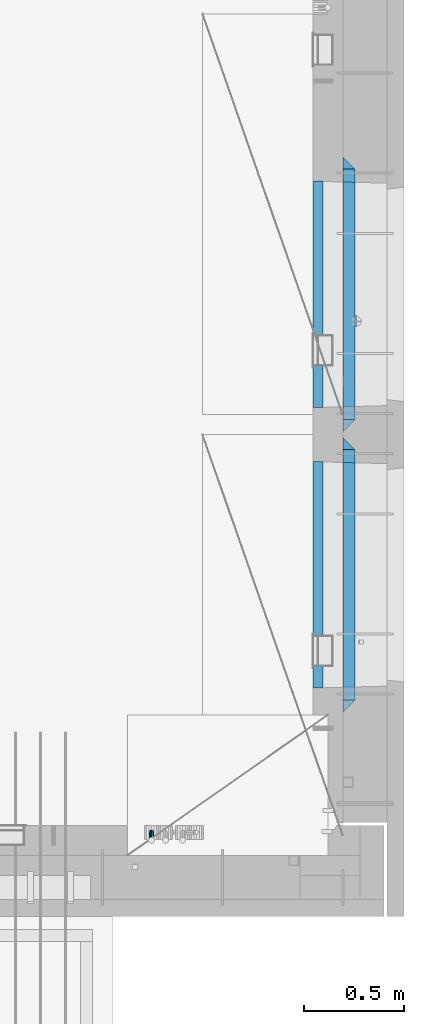
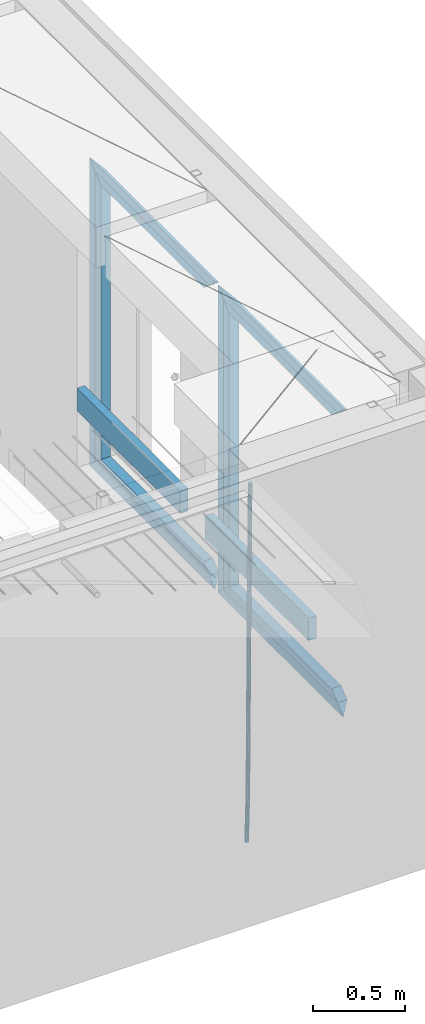
# One storey, part 130 of 352: 15 beams, 2 elements without a shape of their own.
"""IFC2X3 building model written with IfcOpenShell, lengths in millimetres."""

import ifcopenshell
import ifcopenshell.guid

model = None  # the IFC model being written
_history = None  # IfcOwnerHistory: only IFC2X3 demands one
_inside = {}  # id of a spatial element -> (the spatial element, [elements in it])
_under = {}  # id of a project, library or spatial element -> (it, [spatial elements below it])
_declared = {}  # id of a project -> (the project, [libraries it declares])
_typed = {}  # id of a type object -> (the type object, [elements of that type])
_made_of = {}  # id of a material, layer set ... -> (it, [elements and type objects made of it])


def new_model(schema):
    """Start an empty IFC model of exactly this schema.

    Asked for "IFC4X3", IfcOpenShell would pick the latest addendum, in which some entities
    have other attributes; the version numbers below select the first issue.
    IFC2X3 requires an IfcOwnerHistory on every rooted entity: one is made here for all.
    """
    global model, _history
    if schema == "IFC4X3":
        model = ifcopenshell.file(schema_version=(4, 3, 0, 0))
    else:
        model = ifcopenshell.file(schema=schema)
    _inside.clear()
    _under.clear()
    _declared.clear()
    _typed.clear()
    _made_of.clear()
    _history = None
    if model.schema == "IFC2X3":
        org = make("IfcOrganization", Name="unknown")
        user = make(
            "IfcPersonAndOrganization",
            ThePerson=make("IfcPerson", FamilyName="unknown"),
            TheOrganization=org,
        )
        app = make(
            "IfcApplication",
            ApplicationDeveloper=org,
            Version="unknown",
            ApplicationFullName="unknown",
            ApplicationIdentifier="unknown",
        )
        _history = make(
            "IfcOwnerHistory",
            OwningUser=user,
            OwningApplication=app,
            ChangeAction="ADDED",
            CreationDate=0,
        )
    return model


def make(cls, **values):
    """One entity of the class cls with the attributes given. An attribute that is None is left unset."""
    return model.create_entity(
        cls, **{name: value for name, value in values.items() if value is not None}
    )


def rooted(cls, **values):
    """An entity with a GlobalId (a new one), such as an element, a storey or a relation."""
    return make(cls, GlobalId=ifcopenshell.guid.new(), OwnerHistory=_history, **values)


def si_unit(unit_type, name, prefix=None):
    """IfcSIUnit, for example si_unit("LENGTHUNIT", "METRE", prefix="MILLI")."""
    return make("IfcSIUnit", UnitType=unit_type, Prefix=prefix, Name=name)


def assignment(units):
    """IfcUnitAssignment: the units of a project."""
    return None if units is None else make("IfcUnitAssignment", Units=units)


def point(xyz):
    """IfcCartesianPoint."""
    return None if xyz is None else make("IfcCartesianPoint", Coordinates=xyz)


def direction(xyz):
    """IfcDirection."""
    return None if xyz is None else make("IfcDirection", DirectionRatios=xyz)


def frame(location, z_axis=None, x_axis=None):
    """IfcAxis2Placement3D, a coordinate frame: its origin and axes. An axis left out is left unset."""
    return make(
        "IfcAxis2Placement3D",
        Location=point(location),
        Axis=direction(z_axis),
        RefDirection=direction(x_axis),
    )


def origin_with_axes():
    """The frame at (0, 0, 0) with the z axis (0, 0, 1) and the x axis (1, 0, 0) written out."""
    return frame((0.0, 0.0, 0.0), z_axis=(0.0, 0.0, 1.0), x_axis=(1.0, 0.0, 0.0))


def place(relative_to, where):
    """IfcLocalPlacement: puts the frame where relative to a parent placement (None: the world)."""
    return make(
        "IfcLocalPlacement", PlacementRelTo=relative_to, RelativePlacement=where
    )


def context(
    kind, dimensions, precision=None, world=None, true_north=None, identifier=None
):
    """IfcGeometricRepresentationContext, for example the 3D "Model" context."""
    return make(
        "IfcGeometricRepresentationContext",
        ContextIdentifier=identifier,
        ContextType=kind,
        CoordinateSpaceDimension=dimensions,
        Precision=precision,
        WorldCoordinateSystem=world,
        TrueNorth=true_north,
    )


def subcontext(parent, identifier, kind, view, scale=None):
    """IfcGeometricRepresentationSubContext, for example "Body" below "Model"."""
    return make(
        "IfcGeometricRepresentationSubContext",
        ContextIdentifier=identifier,
        ContextType=kind,
        ParentContext=parent,
        TargetScale=scale,
        TargetView=view,
    )


def project(units=None, contexts=None):
    """IfcProject with its units and contexts."""
    return rooted(
        "IfcProject",
        Name="project",
        RepresentationContexts=contexts,
        UnitsInContext=assignment(units),
    )


def spatial(cls, under=None, at=None, **own):
    """A site, building, storey or space (cls), placed at a placement, below another one or the project."""
    s = rooted(cls, ObjectPlacement=at, **own)
    if under is not None:
        _under.setdefault(under.id(), (under, []))[1].append(s)
    return s


def faces_of(points, faces, orient=None, outer=None):
    """IfcFace entities. A face is a list of loops; a loop is a list of indices into points, from 0.

    orient and outer hold one flag for each loop. By default every Orientation is true, the
    first loop of a face is its IfcFaceOuterBound and the others are IfcFaceBound.
    """
    made = []
    for i, loops in enumerate(faces):
        bounds = []
        for j, loop in enumerate(loops):
            is_outer = j == 0 if outer is None else outer[i][j]
            bounds.append(
                make(
                    "IfcFaceOuterBound" if is_outer else "IfcFaceBound",
                    Bound=make("IfcPolyLoop", Polygon=[points[k] for k in loop]),
                    Orientation=True if orient is None else orient[i][j],
                )
            )
        made.append(make("IfcFace", Bounds=bounds))
    return made


def faceted_brep(points, faces, orient=None, outer=None, voids=None):
    """IfcFacetedBrep: a solid bounded by flat faces; with voids (closed shells), ...WithVoids."""
    shared = [point(p) for p in points]
    hull = make("IfcClosedShell", CfsFaces=faces_of(shared, faces, orient, outer))
    if voids is None:
        return make("IfcFacetedBrep", Outer=hull)
    return make(
        "IfcFacetedBrepWithVoids",
        Outer=hull,
        Voids=[
            make(cls, CfsFaces=faces_of(shared, fs, o, b)) for cls, fs, o, b in voids
        ],
    )


def shape(context_of_items, identifier, shape_type, items):
    """IfcShapeRepresentation: the items that make up one representation, for example the "Body"."""
    return make(
        "IfcShapeRepresentation",
        ContextOfItems=context_of_items,
        RepresentationIdentifier=identifier,
        RepresentationType=shape_type,
        Items=items,
    )


def material(Name=None, Category=None):
    """IfcMaterial."""
    return make("IfcMaterial", Name=Name, Category=Category)


def made_of(thing, what):
    """Note that an element or type object is made of a material, layer set ...; save() writes the relation."""
    if what is not None:
        _made_of.setdefault(what.id(), (what, []))[1].append(thing)
    return thing


def type_object(cls, material=None, **own):
    """A type object (cls), such as IfcWallType, which elements share."""
    return made_of(rooted(cls, **own), material)


def element(
    cls,
    number,
    at=None,
    inside=None,
    cuts=None,
    type_object=None,
    material=None,
    context=None,
    identifier="Body",
    shape_type=None,
    held_by="IfcProductDefinitionShape",
    body=None,
    shapes=None,
    **own,
):
    """One element of the class cls, such as IfcWall. Its Tag is "e" and its number.

    at: its placement. inside: the storey or other place that contains it. cuts: it is an
    opening in that element (IfcRelVoidsElement). A single representation is given by context,
    identifier, shape_type and body (its items); several are given by shapes. held_by: the class
    of the entity that holds the representations. save() writes the other relations.
    """
    e = rooted(cls, Tag="e%d" % number, ObjectPlacement=at, **own)
    if body is not None:
        shapes = [shape(context, identifier, shape_type, body)]
    if shapes is not None:
        e.Representation = make(held_by, Representations=shapes)
    if inside is not None:
        _inside.setdefault(inside.id(), (inside, []))[1].append(e)
    if cuts is not None:
        rooted(
            "IfcRelVoidsElement", RelatingBuildingElement=cuts, RelatedOpeningElement=e
        )
    if type_object is not None:
        _typed.setdefault(type_object.id(), (type_object, []))[1].append(e)
    return made_of(e, material)


def aggregate(whole, parts):
    """IfcRelAggregates: a whole, such as a stair, and the parts it consists of."""
    return rooted("IfcRelAggregates", RelatingObject=whole, RelatedObjects=parts)


def save(model, path):
    """Write the relations noted so far, then the file.

    IfcRelAggregates (storeys below a building ...), IfcRelContainedInSpatialStructure (elements
    in a storey), IfcRelDefinesByType, IfcRelAssociatesMaterial and IfcRelDeclares: one each for
    every whole, place, type object, material and project.
    """
    for whole, parts in _under.values():
        aggregate(whole, parts)
    for where, things in _inside.values():
        rooted(
            "IfcRelContainedInSpatialStructure",
            RelatedElements=things,
            RelatingStructure=where,
        )
    for kind, things in _typed.values():
        rooted("IfcRelDefinesByType", RelatedObjects=things, RelatingType=kind)
    for what, things in _made_of.values():
        rooted("IfcRelAssociatesMaterial", RelatedObjects=things, RelatingMaterial=what)
    for by, libraries in _declared.values():
        rooted("IfcRelDeclares", RelatingContext=by, RelatedDefinitions=libraries)
    model.write(path)


model = new_model("IFC2X3")

# Units and contexts
model_context = context("Model", 3, precision=1e-05, world=origin_with_axes())
body_context = subcontext(model_context, "Body", "Model", "MODEL_VIEW")
ifc_project = project(units=[si_unit("LENGTHUNIT", "METRE", prefix="MILLI"), si_unit("AREAUNIT", "SQUARE_METRE"), si_unit("VOLUMEUNIT", "CUBIC_METRE"), si_unit("MASSUNIT", "GRAM", prefix="KILO"), si_unit("TIMEUNIT", "SECOND"), si_unit("PLANEANGLEUNIT", "RADIAN"), si_unit("SOLIDANGLEUNIT", "STERADIAN"), si_unit("THERMODYNAMICTEMPERATUREUNIT", "DEGREE_CELSIUS"), si_unit("LUMINOUSINTENSITYUNIT", "LUMEN")], contexts=[model_context])

# Site, building, storey
site_placement = place(None, origin_with_axes())
site = spatial("IfcSite", under=ifc_project, at=site_placement, CompositionType="ELEMENT")
building_placement = place(site_placement, origin_with_axes())
building = spatial("IfcBuilding", under=site, at=building_placement, CompositionType="ELEMENT")
storey_placement = place(building_placement, origin_with_axes())
storey = spatial("IfcBuildingStorey", under=building, at=storey_placement, Name="6", CompositionType="ELEMENT", Elevation=0.0)

# Assembly, beam
assembly_1_placement = place(storey_placement, origin_with_axes())
assembly_1 = element("IfcElementAssembly", 1, at=assembly_1_placement, inside=storey, AssemblyPlace="NOTDEFINED", PredefinedType="REINFORCEMENT_UNIT")
ifc_material_1 = material()
beam_type_1 = type_object("IfcBeamType", Name="D25", PredefinedType="NOTDEFINED")
beam_1_placement = place(assembly_1_placement, frame((34104.9999999961, 7965.00000227913, 96990.0), z_axis=(0.00020576299992186, -0.999642804629538, -0.0267249099901004), x_axis=(-4.30000201928125e-08, -0.0267249099948059, 0.999642825806181)))
beam_1 = element("IfcBeam", 2, at=beam_1_placement, type_object=beam_type_1, material=ifc_material_1, Name="JM25", ObjectType="D25", context=body_context, shape_type="Brep", body=[
    faceted_brep([(-7.41420080885291e-08, -12.5, -3.63797880709171e-12), (-6.42030499875546e-08, -10.8253175473074, -6.25000000000364), (60.4103898235917, -10.8253175318459, -6.2499999938409), (60.4103898269532, -12.4999999845422, 6.16273609921336e-09), (-3.70782800018787e-08, -6.25000000000364, -10.8253175473074), (60.4103898202884, -6.24999998454587, -10.8253175411446), (-1.45519152283669e-11, -3.63797880709171e-12, -12.5), (60.4103898179019, 1.54577719513327e-08, -12.4999999938373), (3.70637280866504e-08, 6.25, -10.8253175473074), (60.410389817087, 6.25000001545777, -10.825317541141), (6.42030499875546e-08, 10.8253175473001, -6.25000000000364), (60.410389818062, 10.8253175627578, -6.24999999383726), (7.41420080885291e-08, 12.4999999999927, 0.0), (60.4103898205503, 12.5000000154541, 6.16273609921336e-09), (6.42176019027829e-08, 10.8253175473001, 6.24999999999636), (60.4103898238973, 10.8253175627651, 6.2500000061591), (3.70928319171071e-08, 6.24999999999636, 10.8253175473037), (60.4103898272151, 6.25000001546141, 10.8253175534664), (1.45519152283669e-11, -3.63797880709171e-12, 12.4999999999964), (60.4103898296162, 1.54541339725256e-08, 12.5000000061591), (-3.7049176171422e-08, -6.25000000000364, 10.8253175473001), (60.4103898304165, -6.24999998454587, 10.8253175534701), (-6.41884980723262e-08, -10.8253175473074, 6.25), (60.4103898294561, -10.8253175318459, 6.25000000616637), (61.0324985728803, -10.8253175316895, -6.24999999377542), (60.991802792938, -12.4999999843931, 6.22458173893392e-09), (61.0622854283865, -6.24999998437852, -10.8253175410755), (61.0731819955545, 1.5628756955266e-08, -12.4999999937718), (61.0622685480339, 6.25000001562512, -10.8253175410791), (61.032469335245, 10.8253175629216, -6.24999999377178), (60.9917690322181, 12.5000000156033, 6.22458173893392e-09), (60.9510732522613, 10.8253175629034, 6.25000000621731), (60.9212863967696, 6.25000001558874, 10.8253175535247), (60.9103898296162, 1.55814632307738e-08, 12.5000000062137), (60.9213032771368, -6.24999998441126, 10.8253175535174), (60.9511024898966, -10.8253175317113, 6.25000000621731), (61.6545545670233, -10.8253158516927, -6.24189838219536), (61.573166454793, -12.499998414296, 0.00757164385504439), (61.7141257553885, -6.24999822394238, -10.8168280205282), (61.7359179680789, 1.80548886419274e-06, -12.491368569139), (61.7140919992817, 6.25000177601396, -10.8168282403167), (61.6544960997562, 10.8253192428383, -6.2418987628771), (61.5730989426083, 12.5000015856094, 0.0075712042817031), (61.4917108303925, 10.8253190230062, 6.25704123032847), (61.4321396420273, 6.25000139525582, 10.8319708686649), (61.4103474293224, 1.36582457344048e-06, 12.5065114172721), (61.4321733981196, -6.24999860470052, 10.8319710884571), (61.4917692976451, -10.8253160715249, 6.25704161101385), (176.524302641745, -10.8250056210964, -4.74584321979273), (176.442914529529, -12.4996881836996, 1.50362680625403), (176.583873830095, -6.24968799334965, -9.3207728581292), (176.605666042786, 0.000312036081595579, -10.9953134067364), (176.583840074018, 6.25031200660669, -9.32077307791769), (176.524244174492, 10.8256294734347, -4.74584360047811), (176.44284701733, 12.5003118162058, 1.50362636668069), (176.361458905099, 10.8256292535989, 7.75309639272746), (176.301887716749, 6.25031162585219, 12.3280260310676), (176.280095504058, 0.000311596420942806, 14.0025665796711), (176.301921472827, -6.24968837410415, 12.3280262508561), (176.361517372367, -10.8250058409321, 7.75309677341284), (177.085397012124, -10.8250041057399, -4.73853556792164), (176.983633547483, -12.4996867233749, 1.51066909103247), (177.159881729676, -6.24968643771717, -9.31327097355097), (177.187129580227, 0.000313606451527448, -10.987740468332), (177.159839524218, 6.25031356221734, -9.31327130338468), (177.085323910098, 10.8256309887511, -4.73853613920801), (176.983549136537, 12.5003132764905, 1.51066843136869), (176.881785671867, 10.8256306588555, 7.7598730903228), (176.80730095433, 6.25031299082912, 12.3346084959521), (176.780053103794, 0.000312946667690994, 14.0090779907332), (176.807343159802, -6.2496870091054, 12.3346088257895), (176.881858773908, -10.8250044356355, 7.7598736616128), (177.646431799818, -10.8250018318176, -4.72756919822132), (177.524295146417, -12.4996845320202, 1.52123723245313), (177.735828462886, -6.24968410334986, -9.30201312475765), (177.768531371941, 0.00031596292683389, -10.9763759912421), (177.735777808921, 6.25031589654827, -9.30201361973741), (177.646344064575, 10.8256332626152, -4.72757005553649), (177.524193838486, 12.5003154677688, 1.52123624250817), (177.402057185071, 10.8256327675663, 7.77004267317898), (177.312660521988, 6.2503150390985, 12.3444865997226), (177.279957612933, 0.00031497282179771, 14.0188494661961), (177.312711175953, -6.24968496079964, 12.3444870946951), (177.402144920314, -10.8250023268702, 7.77004353049415), (299.377443161706, -10.8245084454466, -2.34813158632096), (299.255306508276, -12.4991911456491, 3.90067484435349), (299.466839824803, -6.24919071697514, -6.92257551286093), (299.499542733873, 0.0008093492979242, -8.59693837933446), (299.466789170867, 6.250809282923, -6.92257600783341), (299.377355426492, 10.8261266489935, -2.34813244364341), (299.255205200388, 12.5008088541435, 3.90067385440125), (299.133068546944, 10.826126153941, 10.1494802850757), (299.043671883861, 6.25080842546959, 14.7239242116229), (299.010968974762, 0.000808359200163977, 16.3982870780892), (299.043722537797, -6.24919157442127, 14.7239247065918), (299.133156282158, -10.8245089404954, 10.1494811423981), (299.98561436501, -10.8245059804758, -2.33624385599614), (299.97179243555, -12.4991882411778, 3.91467976726199), (299.995742293278, -6.24918857328521, -6.91223722345239), (299.999447243041, 0.000811375455668895, -8.58716690387519), (299.995736475976, 6.25081142679483, -6.91223684201032), (299.985604289133, 10.8261291142808, -2.33624319533556), (299.971750386685, 12.5008117588586, 3.91467993563856), (299.957928457196, 10.8261294971744, 10.1656035610831), (299.947800528913, 6.25081208998381, 14.7415969285394), (299.944095579151, 0.00081214124293183, 16.4165266089549), (299.947806346216, -6.24918791008895, 14.7415965471009), (299.957938533058, -10.8245055975785, 10.1656029004225), (300.593832239858, -10.8245078794353, -2.34543881707941), (300.688302931099, -12.4991904788549, 3.90384712594823), (300.524685350189, -6.24919022474205, -6.92023371784308), (300.499390115292, 0.000809814544481924, -8.59472497713432), (300.524724372954, 6.25080977519247, -6.92023401429469), (300.593899829313, 10.8261272150703, -2.34543933054374), (300.688380976673, 12.5008095210287, 3.90384653304136), (300.782851667915, 10.8261269216127, 10.1531324760799), (300.851998557599, 6.25080926691589, 14.7279273768363), (300.877293792495, 0.000809227632998955, 16.4024186361276), (300.851959534804, -6.24919073302226, 14.7279276732806), (300.782784078474, -10.8245081728965, 10.153132989537), (2293.32930409742, -10.8307295605009, -32.4713622331001), (2293.42377478865, -12.5054121599169, -26.2220762900724), (2293.26015720774, -6.2554119058077, -37.0461571338565), (2293.23486197284, -0.00541186651753378, -38.7206483931477), (2293.26019623051, 6.24458809413409, -37.0461574303008), (2293.32937168686, 10.8199055340046, -32.4713627465644), (2293.42385283421, 12.4945878399631, -26.2220768829684), (2293.51832352545, 10.8199052405434, -19.972790939948), (2293.58747041514, 6.24458758585388, -15.3979960391844), (2293.61276565003, -0.00541245343265473, -13.7235047798931), (2293.58743139236, -6.25541241408428, -15.3979957427327), (2293.51825593603, -10.8307298539585, -19.9727904264691), (2294.0420846676, -10.8307317859326, -32.4821379598216), (2294.03681932652, -12.5054140739521, -26.2313442200393), (2294.06778164886, -6.2554144273563, -37.0583666982457), (2294.10702478497, -0.00541458957013674, -38.7338336404937), (2294.14929890928, 6.24458531819619, -37.0595987724118), (2294.18327670435, 10.8199028679592, -32.4842719748667), (2294.1998538474, 12.4945854171456, -26.2338083683717), (2294.19458850632, 10.819903129126, -19.9830146285858), (2294.16889152506, 6.24458577054975, -15.4067858901581), (2294.12964838895, -0.0054140672327776, -13.7313189479173), (2294.08737426462, -6.2554139749991, -15.4055538159919), (2294.05339646956, -10.8307315247621, -19.9808806135297), (2294.75482297382, -10.84002603931, -32.4726521173216), (2294.64982751427, -12.513407826169, -26.2231856868602), (2294.87535820232, -6.26594539088183, -37.0476186524102), (2294.97913588268, -0.0167870967634371, -38.7222267036377), (2295.0383488692, 6.23299192477134, -37.0477663960555), (2295.03713108998, 10.8087684320271, -32.4729080168181), (2294.97580884799, 12.4844668051373, -26.2234811741473), (2294.87081338844, 10.8110850182784, -19.9740147436787), (2294.7502781599, 6.23700436985018, -15.3990482086047), (2294.64650047956, -0.0121539242718427, -13.7244401573698), (2294.58728749304, -6.26193294580662, -15.3989004649666), (2294.58850527227, -10.8377094530588, -19.9737588441894), (2316.44667268227, -11.1228921988077, -32.1839550346631), (2316.34167722271, -12.7962739856739, -25.9344886042054), (2316.56720791078, -6.54881155039038, -36.7589215697517), (2316.67098559113, -0.299653256264719, -38.4335296209792), (2316.73019857766, 5.95012576527006, -36.759069313397), (2316.72898079845, 10.5259022725259, -32.1842109341669), (2316.66765855643, 12.2016006456361, -25.9347840914961), (2316.56266309689, 10.5282188587698, -19.6853176610275), (2316.44212786836, 5.95413821035254, -15.1103511259389), (2316.33835018802, -0.295020083769487, -13.4357430747186), (2316.27913720149, -6.54479910530426, -15.1102033823008), (2316.28035498071, -11.1205756125637, -19.685061761531), (2317.13234804722, -11.1318335458927, -32.1748293731798), (2317.04181141085, -12.8054038787741, -25.9251705100723), (2317.2154741603, -6.5572650749491, -36.7502937866229), (2317.26891617525, -0.307450393454928, -38.4255717558117), (2317.27835434731, 5.94297770185585, -36.7517739018112), (2317.24125972588, 10.5192220504723, -32.1773930078925), (2317.16757178486, 12.1950816748285, -25.9281307404563), (2317.0770351485, 10.5215113419545, -19.6784718773561), (2316.99390903539, 5.94694287101083, -15.1030074639057), (2316.94046702047, -0.302871810494253, -13.4277294947169), (2316.9310288484, -6.55329990579412, -15.1015273487101), (2316.96812346982, -11.1295442544142, -19.6759082426288), (2317.81808136747, -11.1298054502913, -32.1659056455355), (2317.74200467508, -12.803315894289, -25.9160547315114), (2317.86379538118, -6.55536082026447, -36.7418676070083), (2317.8668976831, -0.305700748642266, -38.417815303761), (2317.82655701396, 5.94458339541234, -36.7446799039099), (2317.75358262347, 10.5207330230332, -32.1707766866384), (2317.66752794063, 12.1965725370646, -25.9216793252963), (2317.59145124823, 10.5230620930706, -19.6718284112721), (2317.54573723453, 5.94861746304377, -15.0958664497994), (2317.54263493262, -0.301042608574789, -13.4199187530394), (2317.58297560175, -6.55132675263303, -15.0930541529051), (2317.65594999224, -11.1274763802539, -19.6669573701693), (2417.81884292323, -10.831603083323, -30.8687911350135), (2417.74276623082, -12.505113527317, -24.618940220982), (2417.86455693691, -6.25715845329614, -35.4447530964935), (2417.86765923884, -0.00749838167394046, -37.1207007932499), (2417.82731856969, 6.24278576237703, -35.4475653933878), (2417.75434417921, 10.8189353900088, -30.8736621761236), (2417.66828949639, 12.494774904033, -24.6245648147851), (2417.59221280397, 10.8212644600353, -18.3747139007501), (2417.54649879028, 6.2468198300121, -13.79875193927), (2417.54339648837, -0.00284024161010166, -12.1228042425173), (2417.5837371575, -6.25312438566107, -13.795939642383), (2417.65671154798, -10.8292740132893, -18.3698428596399)], [[[0, 1, 2, 3]], [[1, 4, 5, 2]], [[4, 6, 7, 5]], [[6, 8, 9, 7]], [[8, 10, 11, 9]], [[10, 12, 13, 11]], [[12, 14, 15, 13]], [[14, 16, 17, 15]], [[16, 18, 19, 17]], [[18, 20, 21, 19]], [[20, 22, 23, 21]], [[22, 0, 3, 23]], [[22, 20, 18, 16, 14, 12, 10, 8, 6, 4, 1, 0]], [[3, 2, 24, 25]], [[2, 5, 26, 24]], [[5, 7, 27, 26]], [[7, 9, 28, 27]], [[9, 11, 29, 28]], [[11, 13, 30, 29]], [[13, 15, 31, 30]], [[15, 17, 32, 31]], [[17, 19, 33, 32]], [[19, 21, 34, 33]], [[21, 23, 35, 34]], [[23, 3, 25, 35]], [[25, 24, 36, 37]], [[24, 26, 38, 36]], [[26, 27, 39, 38]], [[27, 28, 40, 39]], [[28, 29, 41, 40]], [[29, 30, 42, 41]], [[30, 31, 43, 42]], [[31, 32, 44, 43]], [[32, 33, 45, 44]], [[33, 34, 46, 45]], [[34, 35, 47, 46]], [[35, 25, 37, 47]], [[37, 36, 48, 49]], [[36, 38, 50, 48]], [[38, 39, 51, 50]], [[39, 40, 52, 51]], [[40, 41, 53, 52]], [[41, 42, 54, 53]], [[42, 43, 55, 54]], [[43, 44, 56, 55]], [[44, 45, 57, 56]], [[45, 46, 58, 57]], [[46, 47, 59, 58]], [[47, 37, 49, 59]], [[49, 48, 60, 61]], [[48, 50, 62, 60]], [[50, 51, 63, 62]], [[51, 52, 64, 63]], [[52, 53, 65, 64]], [[53, 54, 66, 65]], [[54, 55, 67, 66]], [[55, 56, 68, 67]], [[56, 57, 69, 68]], [[57, 58, 70, 69]], [[58, 59, 71, 70]], [[59, 49, 61, 71]], [[61, 60, 72, 73]], [[60, 62, 74, 72]], [[62, 63, 75, 74]], [[63, 64, 76, 75]], [[64, 65, 77, 76]], [[65, 66, 78, 77]], [[66, 67, 79, 78]], [[67, 68, 80, 79]], [[68, 69, 81, 80]], [[69, 70, 82, 81]], [[70, 71, 83, 82]], [[71, 61, 73, 83]], [[73, 72, 84, 85]], [[72, 74, 86, 84]], [[74, 75, 87, 86]], [[75, 76, 88, 87]], [[76, 77, 89, 88]], [[77, 78, 90, 89]], [[78, 79, 91, 90]], [[79, 80, 92, 91]], [[80, 81, 93, 92]], [[81, 82, 94, 93]], [[82, 83, 95, 94]], [[83, 73, 85, 95]], [[85, 84, 96, 97]], [[84, 86, 98, 96]], [[86, 87, 99, 98]], [[87, 88, 100, 99]], [[88, 89, 101, 100]], [[89, 90, 102, 101]], [[90, 91, 103, 102]], [[91, 92, 104, 103]], [[92, 93, 105, 104]], [[93, 94, 106, 105]], [[94, 95, 107, 106]], [[95, 85, 97, 107]], [[97, 96, 108, 109]], [[96, 98, 110, 108]], [[98, 99, 111, 110]], [[99, 100, 112, 111]], [[100, 101, 113, 112]], [[101, 102, 114, 113]], [[102, 103, 115, 114]], [[103, 104, 116, 115]], [[104, 105, 117, 116]], [[105, 106, 118, 117]], [[106, 107, 119, 118]], [[107, 97, 109, 119]], [[109, 108, 120, 121]], [[108, 110, 122, 120]], [[110, 111, 123, 122]], [[111, 112, 124, 123]], [[112, 113, 125, 124]], [[113, 114, 126, 125]], [[114, 115, 127, 126]], [[115, 116, 128, 127]], [[116, 117, 129, 128]], [[117, 118, 130, 129]], [[118, 119, 131, 130]], [[119, 109, 121, 131]], [[121, 120, 132, 133]], [[120, 122, 134, 132]], [[122, 123, 135, 134]], [[123, 124, 136, 135]], [[124, 125, 137, 136]], [[125, 126, 138, 137]], [[126, 127, 139, 138]], [[127, 128, 140, 139]], [[128, 129, 141, 140]], [[129, 130, 142, 141]], [[130, 131, 143, 142]], [[131, 121, 133, 143]], [[133, 132, 144, 145]], [[132, 134, 146, 144]], [[134, 135, 147, 146]], [[135, 136, 148, 147]], [[136, 137, 149, 148]], [[137, 138, 150, 149]], [[138, 139, 151, 150]], [[139, 140, 152, 151]], [[140, 141, 153, 152]], [[141, 142, 154, 153]], [[142, 143, 155, 154]], [[143, 133, 145, 155]], [[145, 144, 156, 157]], [[144, 146, 158, 156]], [[146, 147, 159, 158]], [[147, 148, 160, 159]], [[148, 149, 161, 160]], [[149, 150, 162, 161]], [[150, 151, 163, 162]], [[151, 152, 164, 163]], [[152, 153, 165, 164]], [[153, 154, 166, 165]], [[154, 155, 167, 166]], [[155, 145, 157, 167]], [[157, 156, 168, 169]], [[156, 158, 170, 168]], [[158, 159, 171, 170]], [[159, 160, 172, 171]], [[160, 161, 173, 172]], [[161, 162, 174, 173]], [[162, 163, 175, 174]], [[163, 164, 176, 175]], [[164, 165, 177, 176]], [[165, 166, 178, 177]], [[166, 167, 179, 178]], [[167, 157, 169, 179]], [[169, 168, 180, 181]], [[168, 170, 182, 180]], [[170, 171, 183, 182]], [[171, 172, 184, 183]], [[172, 173, 185, 184]], [[173, 174, 186, 185]], [[174, 175, 187, 186]], [[175, 176, 188, 187]], [[176, 177, 189, 188]], [[177, 178, 190, 189]], [[178, 179, 191, 190]], [[179, 169, 181, 191]], [[181, 180, 192, 193]], [[180, 182, 194, 192]], [[182, 183, 195, 194]], [[183, 184, 196, 195]], [[184, 185, 197, 196]], [[185, 186, 198, 197]], [[186, 187, 199, 198]], [[187, 188, 200, 199]], [[188, 189, 201, 200]], [[189, 190, 202, 201]], [[190, 191, 203, 202]], [[191, 181, 193, 203]], [[194, 195, 196, 197, 198, 199, 200, 201, 202, 203, 193, 192]]]),
])
aggregate(assembly_1, [beam_1])

# Assembly, beams
assembly_2_placement = place(storey_placement, origin_with_axes())
assembly_2 = element("IfcElementAssembly", 3, at=assembly_2_placement, inside=storey, AssemblyPlace="NOTDEFINED", PredefinedType="REINFORCEMENT_UNIT")
ifc_material_2 = material(Name="TIMBER/T24")
beam_type_2 = type_object("IfcBeamType", PredefinedType="NOTDEFINED")
beam_2_placement = place(assembly_2_placement, frame((34935.0002758707, 8685.00118845241, 97685.0), z_axis=(0.0, 0.0, 1.0), x_axis=(0.0, 1.0, 0.0)))
beam_2 = element("IfcBeam", 4, at=beam_2_placement, type_object=beam_type_2, material=ifc_material_2, context=body_context, shape_type="Brep", body=[
    faceted_brep([(-3.63797880709171e-12, 24.9999999999964, -75.0), (-3.63797880709171e-12, 24.9999999999964, 75.0), (1130.0, 25.0, 75.0), (1130.0, 25.0, -75.0), (0.0, -25.0000000000073, 75.0), (1130.0, -25.0, 75.0), (0.0, -25.0000000000073, -75.0), (1130.0, -25.0, -75.0)], [[[0, 1, 2, 3]], [[1, 4, 5, 2]], [[4, 6, 7, 5]], [[6, 0, 3, 7]], [[5, 7, 3, 2]], [[6, 4, 1, 0]]]),
])
beam_3_placement = place(assembly_2_placement, frame((34935.0002758707, 10085.0011884524, 97685.0), z_axis=(0.0, 0.0, 1.0), x_axis=(0.0, 1.0, 0.0)))
beam_3 = element("IfcBeam", 5, at=beam_3_placement, type_object=beam_type_2, material=ifc_material_2, context=body_context, shape_type="Brep", body=[
    faceted_brep([(-3.63797880709171e-12, 24.9999999999964, -75.0), (-3.63797880709171e-12, 24.9999999999964, 75.0), (1130.0, 25.0, 75.0), (1130.0, 25.0, -75.0), (0.0, -25.0000000000073, 75.0), (1130.0, -25.0, 75.0), (0.0, -25.0000000000073, -75.0), (1130.0, -25.0, -75.0)], [[[0, 1, 2, 3]], [[1, 4, 5, 2]], [[4, 6, 7, 5]], [[6, 0, 3, 7]], [[5, 7, 3, 2]], [[6, 4, 1, 0]]]),
])
ifc_material_3 = material(Name="CONCRETE/C25/30")
beam_type_3 = type_object("IfcBeamType", PredefinedType="NOTDEFINED")
beam_4_placement = place(assembly_2_placement, frame((35090.0, 8565.0001381367, 99145.0), z_axis=(0.0, 0.0, -1.0), x_axis=(0.0, 1.0, 0.0)))
beam_4 = element("IfcBeam", 6, at=beam_4_placement, type_object=beam_type_3, material=ifc_material_3, Name="SK", context=body_context, shape_type="Brep", body=[
    faceted_brep([(60.0000000000073, 30.0, 30.0), (0.0, -30.0, -30.0), (60.0000000000073, -30.0, 30.0), (1309.99990463256, 30.0, 30.0), (1369.99990463257, -30.0, -30.0), (1309.99990463256, -30.0, 30.0)], [[[0, 1, 2]], [[1, 0, 3, 4]], [[2, 1, 4, 5]], [[0, 2, 5, 3]], [[4, 3, 5]]]),
])
beam_5_placement = place(assembly_2_placement, frame((35090.0, 8625.0001381367, 99085.0), z_axis=(0.0, 0.0, -1.0), x_axis=(0.0, 1.0, 0.0)))
beam_5 = element("IfcBeam", 7, at=beam_5_placement, type_object=beam_type_3, material=ifc_material_3, Name="SK", context=body_context, shape_type="Brep", body=[
    faceted_brep([(65.6755803082433, 30.0, 25.6756756756804), (64.0539586866216, -30.0, 24.0540540540533), (1185.94585057852, -30.0, 24.0540540540533), (1184.32422895689, 30.0, 25.6756756756804), (65.6755803082433, 30.0, 26.2933545375708), (64.0539586866216, -30.0, 24.9033931479062), (0.0, -30.0, -30.0), (0.0, 30.0, -30.0), (1249.99990463257, 30.0, -30.0), (1249.99990463257, -30.0, -30.0), (1185.94585057852, -30.0, 24.9034748914273), (1184.32422895689, 30.0, 26.293436281092)], [[[0, 1, 2, 3]], [[1, 0, 4, 5]], [[6, 5, 4, 7]], [[6, 7, 8, 9]], [[2, 1, 5, 6, 9, 10]], [[3, 2, 10, 11]], [[7, 4, 0, 3, 11, 8]], [[10, 9, 8, 11]]]),
])
beam_6_placement = place(assembly_2_placement, frame((35090.0, 9905.00004276927, 99175.0), z_axis=(0.0, -1.0, 0.0), x_axis=(0.0, 0.0, -1.0)))
beam_6 = element("IfcBeam", 8, at=beam_6_placement, type_object=beam_type_3, material=ifc_material_3, Name="SK", context=body_context, shape_type="Brep", body=[
    faceted_brep([(60.0000000000073, 30.0, 30.0), (0.0, -30.0, -30.0), (60.0000000000073, -30.0, 30.0), (1995.0, 30.0, 30.0), (2055.0, -30.0, -30.0), (1995.0, -30.0, 30.0)], [[[0, 1, 2]], [[3, 4, 1, 0]], [[4, 5, 2, 1]], [[5, 3, 0, 2]], [[5, 4, 3]]]),
])
beam_7_placement = place(assembly_2_placement, frame((35090.0, 9875.00004276927, 97210.0), z_axis=(0.0, 0.0, 1.0), x_axis=(0.0, -1.0, 0.0)))
beam_7 = element("IfcBeam", 9, at=beam_7_placement, type_object=beam_type_3, material=ifc_material_3, Name="SK", context=body_context, shape_type="Brep", body=[
    faceted_brep([(1185.94594588314, -29.9999988381387, 24.0540541168593), (1184.32432432432, 29.9999988381387, 25.6756756756804), (65.6756756756768, 30.0, 25.6756756756804), (64.0540540540533, -30.0, 24.0540540540533), (1185.94594594595, -30.0, 24.9033931479207), (1184.32432432433, 30.0, 26.2933545375854), (1249.99990463257, -30.0, -30.0), (1249.99990463257, 30.0, -30.0), (0.0, 30.0, -30.0), (65.6756756756768, 30.0, 26.293436281092), (64.0540540540533, -30.0, 24.9034748914419), (0.0, -30.0, -30.0)], [[[0, 1, 2, 3]], [[1, 0, 4, 5]], [[6, 7, 5, 4]], [[2, 1, 5, 7, 8, 9]], [[3, 2, 9, 10]], [[6, 4, 0, 3, 10, 11]], [[11, 8, 7, 6]], [[11, 10, 9, 8]]]),
])
beam_8_placement = place(assembly_2_placement, frame((35090.0, 9935.00004276927, 97150.0), z_axis=(0.0, 0.0, 1.0), x_axis=(0.0, -1.0, 0.0)))
beam_8 = element("IfcBeam", 10, at=beam_8_placement, type_object=beam_type_3, material=ifc_material_3, Name="SK", context=body_context, shape_type="Brep", body=[
    faceted_brep([(1369.99990463257, -30.0, -30.0), (1309.99990463256, 30.0, 30.0), (1309.99990463256, -30.0, 30.0), (60.0000000000073, 30.0, 30.0), (60.0000000000073, -30.0, 30.0), (0.0, -30.0, -30.0)], [[[0, 1, 2]], [[3, 4, 2, 1]], [[4, 5, 0, 2]], [[5, 3, 1, 0]], [[3, 5, 4]]]),
])
beam_9_placement = place(assembly_2_placement, frame((35090.0, 9965.00023350414, 99145.0), z_axis=(0.0, 0.0, -1.0), x_axis=(0.0, 1.0, 0.0)))
beam_9 = element("IfcBeam", 11, at=beam_9_placement, type_object=beam_type_3, material=ifc_material_3, Name="SK", context=body_context, shape_type="Brep", body=[
    faceted_brep([(60.0000000000073, 30.0, 30.0), (0.0, -30.0, -30.0), (60.0000000000073, -30.0, 30.0), (1309.99942779541, 30.0, 30.0), (1369.99942779541, -30.0, -30.0), (1309.99942779541, -30.0, 30.0)], [[[0, 1, 2]], [[1, 0, 3, 4]], [[2, 1, 4, 5]], [[0, 2, 5, 3]], [[4, 3, 5]]]),
])
beam_10_placement = place(assembly_2_placement, frame((35090.0, 10025.0002335041, 99085.0), z_axis=(0.0, 0.0, -1.0), x_axis=(0.0, 1.0, 0.0)))
beam_10 = element("IfcBeam", 12, at=beam_10_placement, type_object=beam_type_3, material=ifc_material_3, Name="SK", context=body_context, shape_type="Brep", body=[
    faceted_brep([(65.6751034710851, 30.0, 25.6756756756804), (64.0534818494634, -30.0, 24.0540540540533), (1185.94537374136, -30.0, 24.0540540540533), (1184.32375211974, 30.0, 25.6756756756804), (65.6751034710851, 30.0, 26.2929458199942), (64.0534818494634, -30.0, 24.9029844303586), (0.0, -30.0, -30.0), (0.0, 30.0, -30.0), (1249.99942779541, 30.0, -30.0), (1249.99942779541, -30.0, -30.0), (1185.94537374136, -30.0, 24.9034748914273), (1184.32375211974, 30.0, 26.293436281092)], [[[0, 1, 2, 3]], [[1, 0, 4, 5]], [[6, 5, 4, 7]], [[6, 7, 8, 9]], [[2, 1, 5, 6, 9, 10]], [[3, 2, 10, 11]], [[7, 4, 0, 3, 11, 8]], [[10, 9, 8, 11]]]),
])
beam_11_placement = place(assembly_2_placement, frame((35090.0, 11304.9996612995, 99175.0), z_axis=(0.0, -1.0, 0.0), x_axis=(0.0, 0.0, -1.0)))
beam_11 = element("IfcBeam", 13, at=beam_11_placement, type_object=beam_type_3, material=ifc_material_3, Name="SK", context=body_context, shape_type="Brep", body=[
    faceted_brep([(60.0000000000073, 30.0, 30.0), (0.0, -30.0, -30.0), (60.0000000000073, -30.0, 30.0), (1995.0, 30.0, 30.0), (2055.0, -30.0, -30.0), (1995.0, -30.0, 30.0)], [[[0, 1, 2]], [[3, 4, 1, 0]], [[4, 5, 2, 1]], [[5, 3, 0, 2]], [[5, 4, 3]]]),
])
beam_12_placement = place(assembly_2_placement, frame((35090.0, 11274.9996612995, 97210.0), z_axis=(0.0, 0.0, 1.0), x_axis=(0.0, -1.0, 0.0)))
beam_12 = element("IfcBeam", 14, at=beam_12_placement, type_object=beam_type_3, material=ifc_material_3, Name="SK", context=body_context, shape_type="Brep", body=[
    faceted_brep([(1185.94594588314, -29.9999988381387, 24.0540541168593), (1184.32432432432, 29.9999988381387, 25.6756756756804), (65.6756756756768, 30.0, 25.6756756756804), (64.0540540540533, -30.0, 24.0540540540533), (1185.94594594595, -30.0, 24.9029844303586), (1184.32432432433, 30.0, 26.2929458200088), (1249.99942779541, -30.0, -30.0), (1249.99942779541, 30.0, -30.0), (0.0, 30.0, -30.0), (65.6756756756768, 30.0, 26.293436281092), (64.0540540540533, -30.0, 24.9034748914419), (0.0, -30.0, -30.0)], [[[0, 1, 2, 3]], [[1, 0, 4, 5]], [[6, 7, 5, 4]], [[2, 1, 5, 7, 8, 9]], [[3, 2, 9, 10]], [[6, 4, 0, 3, 10, 11]], [[11, 8, 7, 6]], [[11, 10, 9, 8]]]),
])
beam_13_placement = place(assembly_2_placement, frame((35090.0, 11334.9996612995, 97150.0), z_axis=(0.0, 0.0, 1.0), x_axis=(0.0, -1.0, 0.0)))
beam_13 = element("IfcBeam", 15, at=beam_13_placement, type_object=beam_type_3, material=ifc_material_3, Name="SK", context=body_context, shape_type="Brep", body=[
    faceted_brep([(1369.99942779541, -30.0, -30.0), (1309.99942779541, 30.0, 30.0), (1309.99942779541, -30.0, 30.0), (60.0000000000073, 30.0, 30.0), (60.0000000000073, -30.0, 30.0), (0.0, -30.0, -30.0)], [[[0, 1, 2]], [[3, 4, 2, 1]], [[4, 5, 0, 2]], [[5, 3, 1, 0]], [[3, 5, 4]]]),
])
beam_type_4 = type_object("IfcBeamType", PredefinedType="NOTDEFINED")
beam_14_placement = place(assembly_2_placement, frame((35090.0, 9840.00004276927, 99115.0), z_axis=(0.0, -1.0, 0.0), x_axis=(0.0, 0.0, -1.0)))
beam_14 = element("IfcBeam", 16, at=beam_14_placement, type_object=beam_type_4, material=ifc_material_3, Name="SK", context=body_context, shape_type="Brep", body=[
    faceted_brep([(0.0, -30.0, -35.0), (54.9034748914273, -30.0, 29.0540540540533), (56.2934362811066, 30.0, 30.6756756756768), (0.0, 30.0, -35.0), (1935.0, 30.0, -35.0), (1935.0, -30.0, -35.0), (1880.09652510857, -30.0, 29.0540540540533), (1878.70656371891, 30.0, 30.6756756756749)], [[[0, 1, 2, 3]], [[4, 5, 0, 3]], [[1, 0, 5, 6]], [[2, 1, 6, 7]], [[3, 2, 7, 4]], [[6, 5, 4, 7]]]),
])
beam_15_placement = place(assembly_2_placement, frame((35090.0, 11239.9996612995, 99115.0), z_axis=(0.0, -1.0, 0.0), x_axis=(0.0, 0.0, -1.0)))
beam_15 = element("IfcBeam", 17, at=beam_15_placement, type_object=beam_type_4, material=ifc_material_3, Name="SK", context=body_context, shape_type="Brep", body=[
    faceted_brep([(0.0, -30.0, -35.0), (54.9034748914273, -30.0, 29.0540540540533), (56.2934362811066, 30.0, 30.6756756756768), (0.0, 30.0, -35.0), (1935.0, 30.0, -35.0), (1935.0, -30.0, -35.0), (1880.09652510857, -30.0, 29.0540540540533), (1878.70656371891, 30.0, 30.6756756756749)], [[[0, 1, 2, 3]], [[4, 5, 0, 3]], [[1, 0, 5, 6]], [[2, 1, 6, 7]], [[3, 2, 7, 4]], [[6, 5, 4, 7]]]),
])
aggregate(assembly_2, [beam_2, beam_3, beam_4, beam_5, beam_6, beam_14, beam_7, beam_8, beam_9, beam_10, beam_11, beam_15, beam_12, beam_13])

save(model, "model.ifc")
